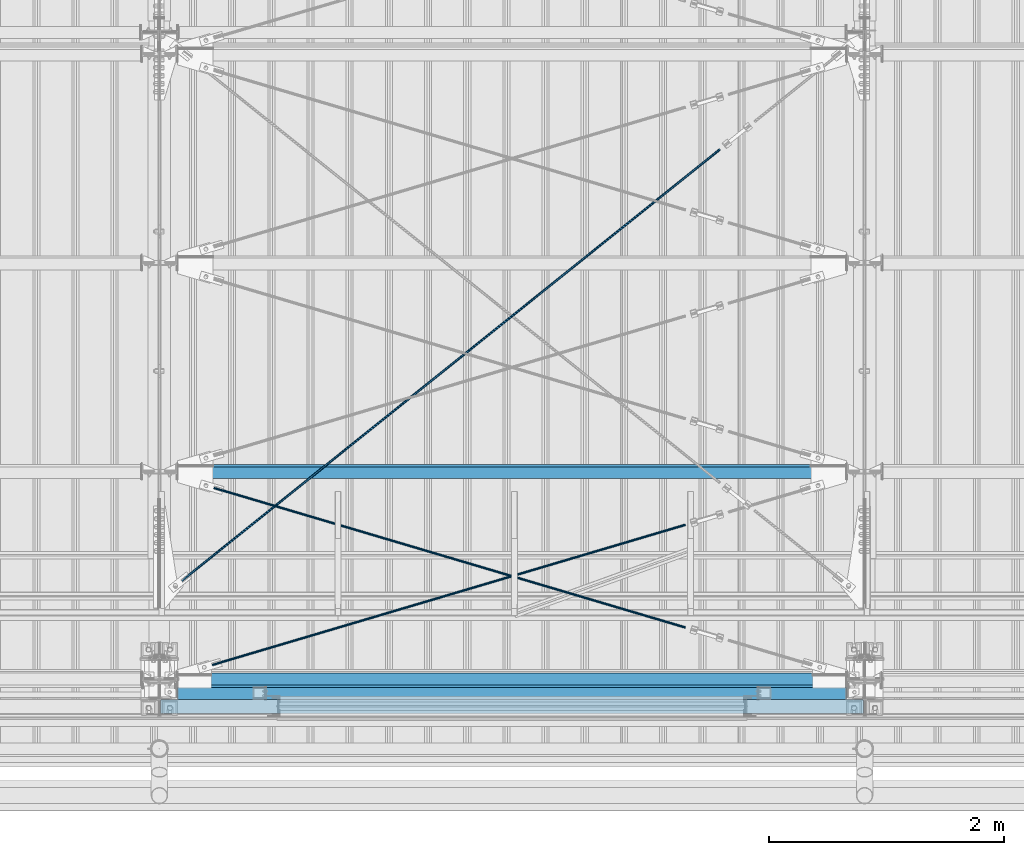
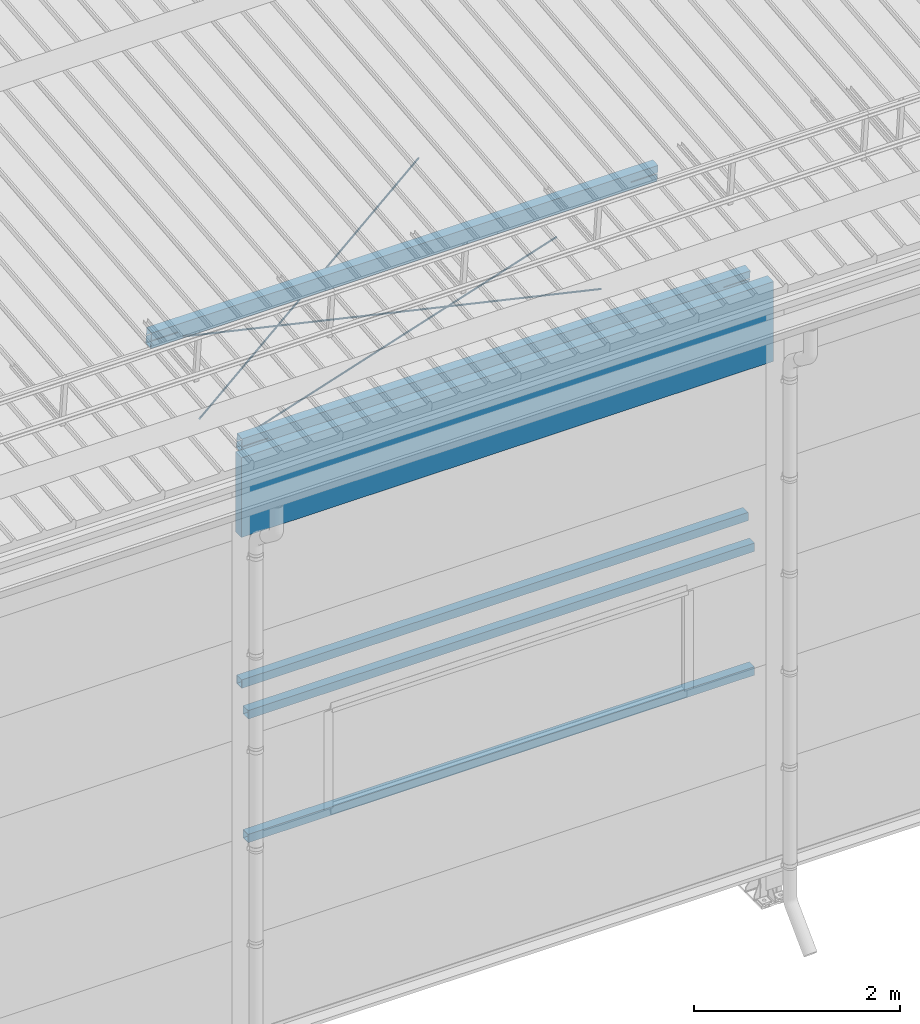
# One storey, part 273 of 709: 9 beams, 7 openings, 9 elements without a shape of their own.
"""IFC4 building model written with IfcOpenShell, lengths in millimetres."""

import ifcopenshell
import ifcopenshell.guid

model = None  # the IFC model being written
_history = None  # IfcOwnerHistory: only IFC2X3 demands one
_inside = {}  # id of a spatial element -> (the spatial element, [elements in it])
_under = {}  # id of a project, library or spatial element -> (it, [spatial elements below it])
_declared = {}  # id of a project -> (the project, [libraries it declares])
_typed = {}  # id of a type object -> (the type object, [elements of that type])
_made_of = {}  # id of a material, layer set ... -> (it, [elements and type objects made of it])


def new_model(schema):
    """Start an empty IFC model of exactly this schema.

    Asked for "IFC4X3", IfcOpenShell would pick the latest addendum, in which some entities
    have other attributes; the version numbers below select the first issue.
    IFC2X3 requires an IfcOwnerHistory on every rooted entity: one is made here for all.
    """
    global model, _history
    if schema == "IFC4X3":
        model = ifcopenshell.file(schema_version=(4, 3, 0, 0))
    else:
        model = ifcopenshell.file(schema=schema)
    _inside.clear()
    _under.clear()
    _declared.clear()
    _typed.clear()
    _made_of.clear()
    _history = None
    if model.schema == "IFC2X3":
        org = make("IfcOrganization", Name="unknown")
        user = make(
            "IfcPersonAndOrganization",
            ThePerson=make("IfcPerson", FamilyName="unknown"),
            TheOrganization=org,
        )
        app = make(
            "IfcApplication",
            ApplicationDeveloper=org,
            Version="unknown",
            ApplicationFullName="unknown",
            ApplicationIdentifier="unknown",
        )
        _history = make(
            "IfcOwnerHistory",
            OwningUser=user,
            OwningApplication=app,
            ChangeAction="ADDED",
            CreationDate=0,
        )
    return model


def make(cls, **values):
    """One entity of the class cls with the attributes given. An attribute that is None is left unset."""
    return model.create_entity(
        cls, **{name: value for name, value in values.items() if value is not None}
    )


def rooted(cls, **values):
    """An entity with a GlobalId (a new one), such as an element, a storey or a relation."""
    return make(cls, GlobalId=ifcopenshell.guid.new(), OwnerHistory=_history, **values)


def si_unit(unit_type, name, prefix=None):
    """IfcSIUnit, for example si_unit("LENGTHUNIT", "METRE", prefix="MILLI")."""
    return make("IfcSIUnit", UnitType=unit_type, Prefix=prefix, Name=name)


def assignment(units):
    """IfcUnitAssignment: the units of a project."""
    return None if units is None else make("IfcUnitAssignment", Units=units)


def point(xyz):
    """IfcCartesianPoint."""
    return None if xyz is None else make("IfcCartesianPoint", Coordinates=xyz)


def direction(xyz):
    """IfcDirection."""
    return None if xyz is None else make("IfcDirection", DirectionRatios=xyz)


def frame(location, z_axis=None, x_axis=None):
    """IfcAxis2Placement3D, a coordinate frame: its origin and axes. An axis left out is left unset."""
    return make(
        "IfcAxis2Placement3D",
        Location=point(location),
        Axis=direction(z_axis),
        RefDirection=direction(x_axis),
    )


def origin_with_axes():
    """The frame at (0, 0, 0) with the z axis (0, 0, 1) and the x axis (1, 0, 0) written out."""
    return frame((0.0, 0.0, 0.0), z_axis=(0.0, 0.0, 1.0), x_axis=(1.0, 0.0, 0.0))


def place(relative_to, where):
    """IfcLocalPlacement: puts the frame where relative to a parent placement (None: the world)."""
    return make(
        "IfcLocalPlacement", PlacementRelTo=relative_to, RelativePlacement=where
    )


def context(
    kind, dimensions, precision=None, world=None, true_north=None, identifier=None
):
    """IfcGeometricRepresentationContext, for example the 3D "Model" context."""
    return make(
        "IfcGeometricRepresentationContext",
        ContextIdentifier=identifier,
        ContextType=kind,
        CoordinateSpaceDimension=dimensions,
        Precision=precision,
        WorldCoordinateSystem=world,
        TrueNorth=true_north,
    )


def subcontext(parent, identifier, kind, view, scale=None):
    """IfcGeometricRepresentationSubContext, for example "Body" below "Model"."""
    return make(
        "IfcGeometricRepresentationSubContext",
        ContextIdentifier=identifier,
        ContextType=kind,
        ParentContext=parent,
        TargetScale=scale,
        TargetView=view,
    )


def project(units=None, contexts=None):
    """IfcProject with its units and contexts."""
    return rooted(
        "IfcProject",
        Name="project",
        RepresentationContexts=contexts,
        UnitsInContext=assignment(units),
    )


def spatial(cls, under=None, at=None, **own):
    """A site, building, storey or space (cls), placed at a placement, below another one or the project."""
    s = rooted(cls, ObjectPlacement=at, **own)
    if under is not None:
        _under.setdefault(under.id(), (under, []))[1].append(s)
    return s


def point_list(points):
    """IfcCartesianPointList2D or 3D."""
    cls = (
        "IfcCartesianPointList2D" if len(points[0]) == 2 else "IfcCartesianPointList3D"
    )
    return make(cls, CoordList=points)


def line(*indices):
    """IfcLineIndex: a straight run through numbered points of an indexed curve."""
    return model.create_entity("IfcLineIndex", indices)


def indexed_curve(points, segments=None, self_intersect=None):
    """IfcIndexedPolyCurve: lines and arcs through numbered points (the first is 1)."""
    return make(
        "IfcIndexedPolyCurve",
        Points=point_list(points),
        Segments=segments,
        SelfIntersect=self_intersect,
    )


def outline(outer, holes=None, kind="AREA"):
    """IfcArbitraryClosedProfileDef: a profile drawn as a closed curve; with holes, ...WithVoids."""
    if holes is None:
        return make("IfcArbitraryClosedProfileDef", ProfileType=kind, OuterCurve=outer)
    return make(
        "IfcArbitraryProfileDefWithVoids",
        ProfileType=kind,
        OuterCurve=outer,
        InnerCurves=holes,
    )


def extrude(swept, where, along, depth):
    """IfcExtrudedAreaSolid: the profile swept, set in the frame where, extruded along a direction by depth."""
    return make(
        "IfcExtrudedAreaSolid",
        SweptArea=swept,
        Position=where,
        ExtrudedDirection=direction(along),
        Depth=depth,
    )


def polygons(points, faces, closed=None, point_numbers=None):
    """IfcPolygonalFaceSet: a face is its outer loop, then its inner loops; points numbered from 1."""
    made = []
    for loops in faces:
        if len(loops) == 1:
            made.append(make("IfcIndexedPolygonalFace", CoordIndex=loops[0]))
        else:
            made.append(
                make(
                    "IfcIndexedPolygonalFaceWithVoids",
                    CoordIndex=loops[0],
                    InnerCoordIndices=loops[1:],
                )
            )
    return make(
        "IfcPolygonalFaceSet",
        Coordinates=point_list(points),
        Closed=closed,
        Faces=made,
        PnIndex=point_numbers,
    )


def shape(context_of_items, identifier, shape_type, items):
    """IfcShapeRepresentation: the items that make up one representation, for example the "Body"."""
    return make(
        "IfcShapeRepresentation",
        ContextOfItems=context_of_items,
        RepresentationIdentifier=identifier,
        RepresentationType=shape_type,
        Items=items,
    )


def material(Name=None, Category=None):
    """IfcMaterial."""
    return make("IfcMaterial", Name=Name, Category=Category)


def made_of(thing, what):
    """Note that an element or type object is made of a material, layer set ...; save() writes the relation."""
    if what is not None:
        _made_of.setdefault(what.id(), (what, []))[1].append(thing)
    return thing


def element(
    cls,
    number,
    at=None,
    inside=None,
    cuts=None,
    type_object=None,
    material=None,
    context=None,
    identifier="Body",
    shape_type=None,
    held_by="IfcProductDefinitionShape",
    body=None,
    shapes=None,
    **own,
):
    """One element of the class cls, such as IfcWall. Its Tag is "e" and its number.

    at: its placement. inside: the storey or other place that contains it. cuts: it is an
    opening in that element (IfcRelVoidsElement). A single representation is given by context,
    identifier, shape_type and body (its items); several are given by shapes. held_by: the class
    of the entity that holds the representations. save() writes the other relations.
    """
    e = rooted(cls, Tag="e%d" % number, ObjectPlacement=at, **own)
    if body is not None:
        shapes = [shape(context, identifier, shape_type, body)]
    if shapes is not None:
        e.Representation = make(held_by, Representations=shapes)
    if inside is not None:
        _inside.setdefault(inside.id(), (inside, []))[1].append(e)
    if cuts is not None:
        rooted(
            "IfcRelVoidsElement", RelatingBuildingElement=cuts, RelatedOpeningElement=e
        )
    if type_object is not None:
        _typed.setdefault(type_object.id(), (type_object, []))[1].append(e)
    return made_of(e, material)


def aggregate(whole, parts):
    """IfcRelAggregates: a whole, such as a stair, and the parts it consists of."""
    return rooted("IfcRelAggregates", RelatingObject=whole, RelatedObjects=parts)


def save(model, path):
    """Write the relations noted so far, then the file.

    IfcRelAggregates (storeys below a building ...), IfcRelContainedInSpatialStructure (elements
    in a storey), IfcRelDefinesByType, IfcRelAssociatesMaterial and IfcRelDeclares: one each for
    every whole, place, type object, material and project.
    """
    for whole, parts in _under.values():
        aggregate(whole, parts)
    for where, things in _inside.values():
        rooted(
            "IfcRelContainedInSpatialStructure",
            RelatedElements=things,
            RelatingStructure=where,
        )
    for kind, things in _typed.values():
        rooted("IfcRelDefinesByType", RelatedObjects=things, RelatingType=kind)
    for what, things in _made_of.values():
        rooted("IfcRelAssociatesMaterial", RelatedObjects=things, RelatingMaterial=what)
    for by, libraries in _declared.values():
        rooted("IfcRelDeclares", RelatingContext=by, RelatedDefinitions=libraries)
    model.write(path)


model = new_model("IFC4")

# Units and contexts
model_context = context("Model", 3, precision=0.2, world=origin_with_axes(), true_north=direction((0.0, 1.0)))
body_context = subcontext(model_context, "Body", "Model", "MODEL_VIEW")
reference_context = subcontext(model_context, "Reference", "Model", "MODEL_VIEW")
ifc_project = project(units=[si_unit("LENGTHUNIT", "METRE", prefix="MILLI"), si_unit("AREAUNIT", "SQUARE_METRE"), si_unit("VOLUMEUNIT", "CUBIC_METRE"), si_unit("MASSUNIT", "GRAM", prefix="KILO"), si_unit("TIMEUNIT", "SECOND"), si_unit("PLANEANGLEUNIT", "RADIAN"), si_unit("SOLIDANGLEUNIT", "STERADIAN"), si_unit("THERMODYNAMICTEMPERATUREUNIT", "DEGREE_CELSIUS"), si_unit("LUMINOUSINTENSITYUNIT", "LUMEN")], contexts=[model_context])

# Site, building, storey
site_placement = place(None, origin_with_axes())
site = spatial("IfcSite", under=ifc_project, at=site_placement, CompositionType="ELEMENT")
building_placement = place(site_placement, origin_with_axes())
building = spatial("IfcBuilding", under=site, at=building_placement, Name="Undefined", CompositionType="ELEMENT")
storey_placement = place(building_placement, origin_with_axes())
storey = spatial("IfcBuildingStorey", under=building, at=storey_placement, Name="Undefined", CompositionType="ELEMENT", Elevation=0.0)

# Assembly, beam, voiding feature
assembly_1_placement = place(storey_placement, frame((40000.0, 855.54834, 6946.69226), z_axis=(0.625451877, -0.7802627439, 1e-10), x_axis=(0.7742288439, 0.6206151549, -0.124123031)))
assembly_1 = element("IfcElementAssembly", 1, at=assembly_1_placement, inside=storey)
ifc_material_1 = material(Name="C355-5", Category="STEEL")
beam_1_placement = place(assembly_1_placement, origin_with_axes())
beam_1 = element("IfcBeam", 2, at=beam_1_placement, material=ifc_material_1, ObjectType="485", context=body_context, shape_type="Tessellation", body=[
    polygons([(6339.64669, 7.36122, 4.25), (6339.64669, 6.01041, 6.01041), (6339.64669, 4.25, 7.36122), (6339.64669, 2.19996, 8.21037), (6339.64669, 0.0, 8.5), (6339.64669, -2.19996, 8.21037), (6339.64669, -4.25, 7.36122), (6339.64669, -6.01041, 6.01041), (6339.64669, -7.36121, 4.25), (6339.64669, -8.21037, 2.19996), (6339.64669, -8.5, 0.0), (6339.64669, -8.21037, -2.19996), (6339.64669, -7.36121, -4.25), (6339.64669, -6.01041, -6.0104), (6339.64669, -4.25, -7.36121), (6339.64669, -2.19996, -8.21037), (6339.64669, 0.0, -8.5), (6339.64669, 2.19996, -8.21037), (6339.64669, 4.25, -7.36121), (6339.64669, 6.01041, -6.0104), (6339.64669, 7.36122, -4.25), (6339.64669, 8.21037, -2.19996), (6339.64669, 8.5, 0.0), (6339.64669, 8.21037, 2.19996), (6159.64669, 8.21037, 2.19996), (6159.64669, 7.36122, 4.25), (6159.64669, 6.01041, 6.01041), (6159.64669, 4.25, 7.36122), (6159.64669, 2.19996, 8.21037), (6159.64669, 0.0, 8.5), (6159.64669, -2.19996, 8.21037), (6159.64669, -4.25, 7.36122), (6159.64669, -6.01041, 6.01041), (6159.64669, -7.36121, 4.25), (6159.64669, -8.21037, 2.19996), (6159.64669, -8.5, 0.0), (6159.64669, -8.21037, -2.19996), (6159.64669, -7.36121, -4.25), (6159.64669, -6.01041, -6.0104), (6159.64669, -4.25, -7.36121), (6159.64669, -2.19996, -8.21037), (6159.64669, 0.0, -8.5), (6159.64669, 2.19996, -8.21037), (6159.64669, 4.25, -7.36121), (6159.64669, 6.01041, -6.0104), (6159.64669, 7.36122, -4.25), (6159.64669, 8.21037, -2.19996), (6159.64669, 8.5, 0.0), (6159.64669, 10.0, 0.0), (6159.64669, 9.65926, 2.58819), (6159.64669, 8.66025, 5.0), (6159.64669, 7.07107, 7.07107), (6159.64669, 5.0, 8.66025), (6159.64669, 2.58819, 9.65926), (6159.64669, 0.0, 10.0), (6159.64669, -2.58819, 9.65926), (6159.64669, -5.0, 8.66025), (6159.64669, -7.07107, 7.07107), (6159.64669, -8.66025, 5.0), (6159.64669, -9.65926, 2.58819), (6159.64669, -10.0, 0.0), (6159.64669, -9.65926, -2.58819), (6159.64669, -8.66025, -5.0), (6159.64669, -7.07107, -7.07107), (6159.64669, -5.0, -8.66025), (6159.64669, -2.58819, -9.65926), (6159.64669, 0.0, -10.0), (6159.64669, 2.58819, -9.65926), (6159.64669, 5.0, -8.66025), (6159.64669, 7.07107, -7.07107), (6159.64669, 8.66025, -5.0), (6159.64669, 9.65926, -2.58819), (246.65866, 2.58819, 9.65926), (246.65866, 5.0, 8.66025), (246.65866, 7.07107, 7.07107), (246.65866, 8.66025, 5.0), (246.65866, 9.65926, 2.58819), (246.65866, 10.0, 0.0), (246.65866, 9.65926, -2.58819), (246.65866, 8.66025, -5.0), (246.65866, 7.07107, -7.07107), (246.65866, 5.0, -8.66025), (246.65866, 2.58819, -9.65926), (246.65866, 0.0, -10.0), (246.65866, -2.58819, -9.65926), (246.65866, -5.0, -8.66025), (246.65866, -7.07107, -7.07107), (246.65866, -8.66025, -5.0), (246.65866, -9.65926, -2.58819), (246.65866, -10.0, 0.0), (246.65866, -9.65926, 2.58819), (246.65866, -8.66025, 5.0), (246.65866, -7.07107, 7.07107), (246.65866, -5.0, 8.66025), (246.65866, -2.58819, 9.65926), (246.65866, 0.0, 10.0)], [[[1, 2, 3, 4, 5, 6, 7, 8, 9, 10, 11, 12, 13, 14, 15, 16, 17, 18, 19, 20, 21, 22, 23, 24]], [[24, 25, 26, 1]], [[1, 26, 27, 2]], [[2, 27, 28, 3]], [[3, 28, 29, 4]], [[4, 29, 30, 5]], [[5, 30, 31, 6]], [[6, 31, 32, 7]], [[7, 32, 33, 8]], [[8, 33, 34, 9]], [[9, 34, 35, 10]], [[10, 35, 36, 11]], [[11, 36, 37, 12]], [[12, 37, 38, 13]], [[13, 38, 39, 14]], [[14, 39, 40, 15]], [[15, 40, 41, 16]], [[16, 41, 42, 17]], [[17, 42, 43, 18]], [[18, 43, 44, 19]], [[19, 44, 45, 20]], [[20, 45, 46, 21]], [[21, 46, 47, 22]], [[22, 47, 48, 23]], [[23, 48, 25, 24]], [[49, 50, 51, 52, 53, 54, 55, 56, 57, 58, 59, 60, 61, 62, 63, 64, 65, 66, 67, 68, 69, 70, 71, 72], [47, 46, 45, 44, 43, 42, 41, 40, 39, 38, 37, 36, 35, 34, 33, 32, 31, 30, 29, 28, 27, 26, 25, 48]], [[73, 74, 75, 76, 77, 78, 79, 80, 81, 82, 83, 84, 85, 86, 87, 88, 89, 90, 91, 92, 93, 94, 95, 96]], [[79, 78, 49, 72]], [[80, 79, 72, 71]], [[81, 80, 71, 70]], [[82, 81, 70, 69]], [[83, 82, 69, 68]], [[84, 83, 68, 67]], [[85, 84, 67, 66]], [[86, 85, 66, 65]], [[87, 86, 65, 64]], [[88, 87, 64, 63]], [[89, 88, 63, 62]], [[90, 89, 62, 61]], [[91, 90, 61, 60]], [[92, 91, 60, 59]], [[93, 92, 59, 58]], [[94, 93, 58, 57]], [[95, 94, 57, 56]], [[96, 95, 56, 55]], [[73, 96, 55, 54]], [[74, 73, 54, 53]], [[75, 74, 53, 52]], [[76, 75, 52, 51]], [[77, 76, 51, 50]], [[78, 77, 50, 49]]], closed=True),
])
voiding_feature_1_placement = place(beam_1_placement, frame((6339.64669, 0.0, 0.0), z_axis=(0.0, 1.0, 0.0), x_axis=(-1.0, 0.0, 0.0)))
element("IfcVoidingFeature", 3, at=voiding_feature_1_placement, cuts=beam_1, PredefinedType="HOLE", context=reference_context, identifier="Reference", shape_type="SolidModel", body=[
    extrude(outline(indexed_curve([(10.5, 0.0), (10.14222, 2.7176), (9.09327, 5.25), (7.42462, 7.42462), (5.25, 9.09327), (2.7176, 10.14222), (0.0, 10.5), (-2.7176, 10.14222), (-5.25, 9.09327), (-7.42462, 7.42462), (-9.09327, 5.25), (-10.14222, 2.7176), (-10.5, 0.0), (-10.14222, -2.7176), (-9.09327, -5.25), (-7.42462, -7.42462), (-5.25, -9.09327), (-2.7176, -10.14222), (0.0, -10.5), (2.7176, -10.14222), (5.25, -9.09327), (7.42462, -7.42462), (9.09327, -5.25), (10.14222, -2.7176)], segments=[line(1, 2, 3, 4, 5, 6, 7, 8, 9, 10, 11, 12, 13, 14, 15, 16, 17, 18, 19, 20, 21, 22, 23, 24, 1)])), frame((0.0, 0.0, 0.0), z_axis=(-1.0, 0.0, 0.0), x_axis=(0.0, 0.0, 1.0)), (0.0, 0.0, -1.0), 180.0),
])
aggregate(assembly_1, [beam_1])

# Assembly, beam
assembly_2_placement = place(storey_placement, frame((40000.0, 50.0, 2550.0), z_axis=(0.0, 0.0, -1.0), x_axis=(1.0, 0.0, 0.0)))
assembly_2 = element("IfcElementAssembly", 4, at=assembly_2_placement, inside=storey)
ifc_material_2 = material(Name="C355", Category="STEEL")
beam_2_placement = place(assembly_2_placement, origin_with_axes())
beam_2 = element("IfcBeam", 5, at=beam_2_placement, material=ifc_material_2, ObjectType="545", context=body_context, shape_type="Tessellation", body=[
    polygons([(155.0, -47.0, -47.0), (155.0, -47.0, 47.0), (5845.0, -47.0, 47.0), (5845.0, -47.0, -47.0), (155.0, 47.0, 47.0), (5845.0, 47.0, 47.0), (155.0, 47.0, -47.0), (5845.0, 47.0, -47.0), (155.0, -50.0, -50.0), (155.0, 50.0, -50.0), (5845.0, 50.0, -50.0), (5845.0, -50.0, -50.0), (155.0, 50.0, 50.0), (5845.0, 50.0, 50.0), (155.0, -50.0, 50.0), (5845.0, -50.0, 50.0)], [[[1, 2, 3, 4]], [[2, 5, 6, 3]], [[5, 7, 8, 6]], [[7, 1, 4, 8]], [[9, 10, 11, 12]], [[10, 13, 14, 11]], [[13, 15, 16, 14]], [[15, 9, 12, 16]], [[14, 16, 12, 11], [6, 8, 4, 3]], [[15, 13, 10, 9], [7, 5, 2, 1]]], closed=True),
])
aggregate(assembly_2, [beam_2])

assembly_3_placement = place(storey_placement, frame((40000.0, 50.0, 4020.0), z_axis=(0.0, 0.0, -1.0), x_axis=(1.0, 0.0, 0.0)))
assembly_3 = element("IfcElementAssembly", 6, at=assembly_3_placement, inside=storey)
beam_3_placement = place(assembly_3_placement, origin_with_axes())
beam_3 = element("IfcBeam", 7, at=beam_3_placement, material=ifc_material_2, ObjectType="545", context=body_context, shape_type="Tessellation", body=[
    polygons([(155.0, -47.0, -47.0), (155.0, -47.0, 47.0), (5845.0, -47.0, 47.0), (5845.0, -47.0, -47.0), (155.0, 47.0, 47.0), (5845.0, 47.0, 47.0), (155.0, 47.0, -47.0), (5845.0, 47.0, -47.0), (155.0, -50.0, -50.0), (155.0, 50.0, -50.0), (5845.0, 50.0, -50.0), (5845.0, -50.0, -50.0), (155.0, 50.0, 50.0), (5845.0, 50.0, 50.0), (155.0, -50.0, 50.0), (5845.0, -50.0, 50.0)], [[[1, 2, 3, 4]], [[2, 5, 6, 3]], [[5, 7, 8, 6]], [[7, 1, 4, 8]], [[9, 10, 11, 12]], [[10, 13, 14, 11]], [[13, 15, 16, 14]], [[15, 9, 12, 16]], [[14, 16, 12, 11], [6, 8, 4, 3]], [[15, 13, 10, 9], [7, 5, 2, 1]]], closed=True),
])
aggregate(assembly_3, [beam_3])

assembly_4_placement = place(storey_placement, frame((40000.0, 173.0, 4310.0), z_axis=(0.0, 0.0, -1.0), x_axis=(1.0, 0.0, 0.0)))
assembly_4 = element("IfcElementAssembly", 8, at=assembly_4_placement, inside=storey)
beam_4_placement = place(assembly_4_placement, origin_with_axes())
beam_4 = element("IfcBeam", 9, at=beam_4_placement, material=ifc_material_2, ObjectType="546", context=body_context, shape_type="Tessellation", body=[
    polygons([(155.0, -47.0, -47.0), (155.0, -47.0, 47.0), (5845.0, -47.0, 47.0), (5845.0, -47.0, -47.0), (155.0, 47.0, 47.0), (5845.0, 47.0, 47.0), (155.0, 47.0, -47.0), (5845.0, 47.0, -47.0), (155.0, -50.0, -50.0), (155.0, 50.0, -50.0), (5845.0, 50.0, -50.0), (5845.0, -50.0, -50.0), (155.0, 50.0, 50.0), (5845.0, 50.0, 50.0), (155.0, -50.0, 50.0), (5845.0, -50.0, 50.0)], [[[1, 2, 3, 4]], [[2, 5, 6, 3]], [[5, 7, 8, 6]], [[7, 1, 4, 8]], [[9, 10, 11, 12]], [[10, 13, 14, 11]], [[13, 15, 16, 14]], [[15, 9, 12, 16]], [[14, 16, 12, 11], [6, 8, 4, 3]], [[15, 13, 10, 9], [7, 5, 2, 1]]], closed=True),
])
aggregate(assembly_4, [beam_4])

# Assembly, beam, voiding feature
assembly_5_placement = place(storey_placement, frame((40000.0, 159.15434, 7152.41945), z_axis=(0.2852311229, -0.9537021177, -0.0953702118), x_axis=(0.9584587662, 0.2838155751, 0.028381558)))
assembly_5 = element("IfcElementAssembly", 10, at=assembly_5_placement, inside=storey)
beam_5_placement = place(assembly_5_placement, origin_with_axes())
beam_5 = element("IfcBeam", 11, at=beam_5_placement, material=ifc_material_1, ObjectType="568", context=body_context, shape_type="Tessellation", body=[
    polygons([(4850.05021, 7.36121, 4.25), (4850.05021, 6.01041, 6.01041), (4850.05021, 4.25, 7.36122), (4850.05021, 2.19996, 8.21037), (4850.05021, 0.0, 8.5), (4850.05021, -2.19996, 8.21037), (4850.05021, -4.25, 7.36122), (4850.05021, -6.01041, 6.01041), (4850.05021, -7.36122, 4.25), (4850.05021, -8.21037, 2.19996), (4850.05021, -8.5, 0.0), (4850.05021, -8.21037, -2.19996), (4850.05021, -7.36122, -4.25), (4850.05021, -6.01041, -6.01041), (4850.05021, -4.25, -7.36121), (4850.05021, -2.19996, -8.21037), (4850.05021, 0.0, -8.5), (4850.05021, 2.19996, -8.21037), (4850.05021, 4.25, -7.36121), (4850.05021, 6.01041, -6.01041), (4850.05021, 7.36121, -4.25), (4850.05021, 8.21037, -2.19996), (4850.05021, 8.5, 0.0), (4850.05021, 8.21037, 2.19996), (4670.05021, 8.21037, 2.19996), (4670.05021, 7.36121, 4.25), (4670.05021, 6.01041, 6.01041), (4670.05021, 4.25, 7.36122), (4670.05021, 2.19996, 8.21037), (4670.05021, 0.0, 8.5), (4670.05021, -2.19996, 8.21037), (4670.05021, -4.25, 7.36122), (4670.05021, -6.01041, 6.01041), (4670.05021, -7.36122, 4.25), (4670.05021, -8.21037, 2.19996), (4670.05021, -8.5, 0.0), (4670.05021, -8.21037, -2.19996), (4670.05021, -7.36122, -4.25), (4670.05021, -6.01041, -6.01041), (4670.05021, -4.25, -7.36121), (4670.05021, -2.19996, -8.21037), (4670.05021, 0.0, -8.5), (4670.05021, 2.19996, -8.21037), (4670.05021, 4.25, -7.36121), (4670.05021, 6.01041, -6.01041), (4670.05021, 7.36121, -4.25), (4670.05021, 8.21037, -2.19996), (4670.05021, 8.5, 0.0), (4670.05021, 10.0, 0.0), (4670.05021, 9.65926, 2.58819), (4670.05021, 8.66025, 5.0), (4670.05021, 7.07107, 7.07107), (4670.05021, 5.0, 8.66025), (4670.05021, 2.58819, 9.65926), (4670.05021, 0.0, 10.0), (4670.05021, -2.58819, 9.65926), (4670.05021, -5.0, 8.66025), (4670.05021, -7.07107, 7.07107), (4670.05021, -8.66025, 5.0), (4670.05021, -9.65926, 2.58819), (4670.05021, -10.0, 0.0), (4670.05021, -9.65926, -2.58819), (4670.05021, -8.66025, -5.0), (4670.05021, -7.07107, -7.07107), (4670.05021, -5.0, -8.66025), (4670.05021, -2.58819, -9.65926), (4670.05021, 0.0, -10.0), (4670.05021, 2.58819, -9.65926), (4670.05021, 5.0, -8.66025), (4670.05021, 7.07107, -7.07107), (4670.05021, 8.66025, -5.0), (4670.05021, 9.65926, -2.58819), (468.0251, 2.58819, 9.65926), (468.0251, 5.0, 8.66025), (468.0251, 7.07107, 7.07107), (468.0251, 8.66025, 5.0), (468.0251, 9.65926, 2.58819), (468.0251, 10.0, 0.0), (468.0251, 9.65926, -2.58819), (468.0251, 8.66025, -5.0), (468.0251, 7.07107, -7.07107), (468.0251, 5.0, -8.66025), (468.0251, 2.58819, -9.65926), (468.0251, 0.0, -10.0), (468.0251, -2.58819, -9.65926), (468.0251, -5.0, -8.66025), (468.0251, -7.07107, -7.07107), (468.0251, -8.66025, -5.0), (468.0251, -9.65926, -2.58819), (468.0251, -10.0, 0.0), (468.0251, -9.65926, 2.58819), (468.0251, -8.66025, 5.0), (468.0251, -7.07107, 7.07107), (468.0251, -5.0, 8.66025), (468.0251, -2.58819, 9.65926), (468.0251, 0.0, 10.0)], [[[1, 2, 3, 4, 5, 6, 7, 8, 9, 10, 11, 12, 13, 14, 15, 16, 17, 18, 19, 20, 21, 22, 23, 24]], [[24, 25, 26, 1]], [[1, 26, 27, 2]], [[2, 27, 28, 3]], [[3, 28, 29, 4]], [[4, 29, 30, 5]], [[5, 30, 31, 6]], [[6, 31, 32, 7]], [[7, 32, 33, 8]], [[8, 33, 34, 9]], [[9, 34, 35, 10]], [[10, 35, 36, 11]], [[11, 36, 37, 12]], [[12, 37, 38, 13]], [[13, 38, 39, 14]], [[14, 39, 40, 15]], [[15, 40, 41, 16]], [[16, 41, 42, 17]], [[17, 42, 43, 18]], [[18, 43, 44, 19]], [[19, 44, 45, 20]], [[20, 45, 46, 21]], [[21, 46, 47, 22]], [[22, 47, 48, 23]], [[23, 48, 25, 24]], [[49, 50, 51, 52, 53, 54, 55, 56, 57, 58, 59, 60, 61, 62, 63, 64, 65, 66, 67, 68, 69, 70, 71, 72], [47, 46, 45, 44, 43, 42, 41, 40, 39, 38, 37, 36, 35, 34, 33, 32, 31, 30, 29, 28, 27, 26, 25, 48]], [[73, 74, 75, 76, 77, 78, 79, 80, 81, 82, 83, 84, 85, 86, 87, 88, 89, 90, 91, 92, 93, 94, 95, 96]], [[79, 78, 49, 72]], [[80, 79, 72, 71]], [[81, 80, 71, 70]], [[82, 81, 70, 69]], [[83, 82, 69, 68]], [[84, 83, 68, 67]], [[85, 84, 67, 66]], [[86, 85, 66, 65]], [[87, 86, 65, 64]], [[88, 87, 64, 63]], [[89, 88, 63, 62]], [[90, 89, 62, 61]], [[91, 90, 61, 60]], [[92, 91, 60, 59]], [[93, 92, 59, 58]], [[94, 93, 58, 57]], [[95, 94, 57, 56]], [[96, 95, 56, 55]], [[73, 96, 55, 54]], [[74, 73, 54, 53]], [[75, 74, 53, 52]], [[76, 75, 52, 51]], [[77, 76, 51, 50]], [[78, 77, 50, 49]]], closed=True),
])
voiding_feature_2_placement = place(beam_5_placement, frame((4850.05021, 0.0, 0.0), z_axis=(0.0, 1.0, 0.0), x_axis=(-1.0, 0.0, 0.0)))
element("IfcVoidingFeature", 12, at=voiding_feature_2_placement, cuts=beam_5, PredefinedType="HOLE", context=reference_context, identifier="Reference", shape_type="SolidModel", body=[
    extrude(outline(indexed_curve([(10.5, 0.0), (10.14222, 2.7176), (9.09327, 5.25), (7.42462, 7.42462), (5.25, 9.09327), (2.7176, 10.14222), (0.0, 10.5), (-2.7176, 10.14222), (-5.25, 9.09327), (-7.42462, 7.42462), (-9.09327, 5.25), (-10.14222, 2.7176), (-10.5, 0.0), (-10.14222, -2.7176), (-9.09327, -5.25), (-7.42462, -7.42462), (-5.25, -9.09327), (-2.7176, -10.14222), (0.0, -10.5), (2.7176, -10.14222), (5.25, -9.09327), (7.42462, -7.42462), (9.09327, -5.25), (10.14222, -2.7176)], segments=[line(1, 2, 3, 4, 5, 6, 7, 8, 9, 10, 11, 12, 13, 14, 15, 16, 17, 18, 19, 20, 21, 22, 23, 24, 1)])), frame((0.0, 0.0, 0.0), z_axis=(-1.0, 0.0, 0.0), x_axis=(0.0, 0.0, 1.0)), (0.0, 0.0, -1.0), 180.0),
])
aggregate(assembly_5, [beam_5])

assembly_6_placement = place(storey_placement, frame((40000.0, 1935.85409, 7330.08943), z_axis=(-0.2852311229, -0.9537021177, -0.0953702118), x_axis=(0.9584587662, -0.2838155751, -0.028381558)))
assembly_6 = element("IfcElementAssembly", 13, at=assembly_6_placement, inside=storey)
beam_6_placement = place(assembly_6_placement, origin_with_axes())
beam_6 = element("IfcBeam", 14, at=beam_6_placement, material=ifc_material_1, ObjectType="570", context=body_context, shape_type="Tessellation", body=[
    polygons([(4850.05021, 7.36122, 4.25), (4850.05021, 6.01041, 6.01041), (4850.05021, 4.25, 7.36121), (4850.05021, 2.19996, 8.21037), (4850.05021, 0.0, 8.5), (4850.05021, -2.19996, 8.21037), (4850.05021, -4.25, 7.36121), (4850.05021, -6.01041, 6.01041), (4850.05021, -7.36121, 4.25), (4850.05021, -8.21037, 2.19996), (4850.05021, -8.5, 0.0), (4850.05021, -8.21037, -2.19996), (4850.05021, -7.36121, -4.25), (4850.05021, -6.01041, -6.01041), (4850.05021, -4.25, -7.36122), (4850.05021, -2.19996, -8.21037), (4850.05021, 0.0, -8.5), (4850.05021, 2.19996, -8.21037), (4850.05021, 4.25, -7.36122), (4850.05021, 6.01041, -6.01041), (4850.05021, 7.36122, -4.25), (4850.05021, 8.21037, -2.19996), (4850.05021, 8.5, 0.0), (4850.05021, 8.21037, 2.19996), (4670.05021, 8.21037, 2.19996), (4670.05021, 7.36122, 4.25), (4670.05021, 6.01041, 6.01041), (4670.05021, 4.25, 7.36121), (4670.05021, 2.19996, 8.21037), (4670.05021, 0.0, 8.5), (4670.05021, -2.19996, 8.21037), (4670.05021, -4.25, 7.36121), (4670.05021, -6.01041, 6.01041), (4670.05021, -7.36121, 4.25), (4670.05021, -8.21037, 2.19996), (4670.05021, -8.5, 0.0), (4670.05021, -8.21037, -2.19996), (4670.05021, -7.36121, -4.25), (4670.05021, -6.01041, -6.01041), (4670.05021, -4.25, -7.36122), (4670.05021, -2.19996, -8.21037), (4670.05021, 0.0, -8.5), (4670.05021, 2.19996, -8.21037), (4670.05021, 4.25, -7.36122), (4670.05021, 6.01041, -6.01041), (4670.05021, 7.36122, -4.25), (4670.05021, 8.21037, -2.19996), (4670.05021, 8.5, 0.0), (4670.05021, 10.0, 0.0), (4670.05021, 9.65926, 2.58819), (4670.05021, 8.66025, 5.0), (4670.05021, 7.07107, 7.07107), (4670.05021, 5.0, 8.66025), (4670.05021, 2.58819, 9.65926), (4670.05021, 0.0, 10.0), (4670.05021, -2.58819, 9.65926), (4670.05021, -5.0, 8.66025), (4670.05021, -7.07107, 7.07107), (4670.05021, -8.66025, 5.0), (4670.05021, -9.65926, 2.58819), (4670.05021, -10.0, 0.0), (4670.05021, -9.65926, -2.58819), (4670.05021, -8.66025, -5.0), (4670.05021, -7.07107, -7.07107), (4670.05021, -5.0, -8.66025), (4670.05021, -2.58819, -9.65926), (4670.05021, 0.0, -10.0), (4670.05021, 2.58819, -9.65926), (4670.05021, 5.0, -8.66025), (4670.05021, 7.07107, -7.07107), (4670.05021, 8.66025, -5.0), (4670.05021, 9.65926, -2.58819), (483.0251, 2.58819, 9.65926), (483.0251, 5.0, 8.66025), (483.0251, 7.07107, 7.07107), (483.0251, 8.66025, 5.0), (483.0251, 9.65926, 2.58819), (483.0251, 10.0, 0.0), (483.0251, 9.65926, -2.58819), (483.0251, 8.66025, -5.0), (483.0251, 7.07107, -7.07107), (483.0251, 5.0, -8.66025), (483.0251, 2.58819, -9.65926), (483.0251, 0.0, -10.0), (483.0251, -2.58819, -9.65926), (483.0251, -5.0, -8.66025), (483.0251, -7.07107, -7.07107), (483.0251, -8.66025, -5.0), (483.0251, -9.65926, -2.58819), (483.0251, -10.0, 0.0), (483.0251, -9.65926, 2.58819), (483.0251, -8.66025, 5.0), (483.0251, -7.07107, 7.07107), (483.0251, -5.0, 8.66025), (483.0251, -2.58819, 9.65926), (483.0251, 0.0, 10.0)], [[[1, 2, 3, 4, 5, 6, 7, 8, 9, 10, 11, 12, 13, 14, 15, 16, 17, 18, 19, 20, 21, 22, 23, 24]], [[24, 25, 26, 1]], [[1, 26, 27, 2]], [[2, 27, 28, 3]], [[3, 28, 29, 4]], [[4, 29, 30, 5]], [[5, 30, 31, 6]], [[6, 31, 32, 7]], [[7, 32, 33, 8]], [[8, 33, 34, 9]], [[9, 34, 35, 10]], [[10, 35, 36, 11]], [[11, 36, 37, 12]], [[12, 37, 38, 13]], [[13, 38, 39, 14]], [[14, 39, 40, 15]], [[15, 40, 41, 16]], [[16, 41, 42, 17]], [[17, 42, 43, 18]], [[18, 43, 44, 19]], [[19, 44, 45, 20]], [[20, 45, 46, 21]], [[21, 46, 47, 22]], [[22, 47, 48, 23]], [[23, 48, 25, 24]], [[49, 50, 51, 52, 53, 54, 55, 56, 57, 58, 59, 60, 61, 62, 63, 64, 65, 66, 67, 68, 69, 70, 71, 72], [47, 46, 45, 44, 43, 42, 41, 40, 39, 38, 37, 36, 35, 34, 33, 32, 31, 30, 29, 28, 27, 26, 25, 48]], [[73, 74, 75, 76, 77, 78, 79, 80, 81, 82, 83, 84, 85, 86, 87, 88, 89, 90, 91, 92, 93, 94, 95, 96]], [[79, 78, 49, 72]], [[80, 79, 72, 71]], [[81, 80, 71, 70]], [[82, 81, 70, 69]], [[83, 82, 69, 68]], [[84, 83, 68, 67]], [[85, 84, 67, 66]], [[86, 85, 66, 65]], [[87, 86, 65, 64]], [[88, 87, 64, 63]], [[89, 88, 63, 62]], [[90, 89, 62, 61]], [[91, 90, 61, 60]], [[92, 91, 60, 59]], [[93, 92, 59, 58]], [[94, 93, 58, 57]], [[95, 94, 57, 56]], [[96, 95, 56, 55]], [[73, 96, 55, 54]], [[74, 73, 54, 53]], [[75, 74, 53, 52]], [[76, 75, 52, 51]], [[77, 76, 51, 50]], [[78, 77, 50, 49]]], closed=True),
])
voiding_feature_3_placement = place(beam_6_placement, frame((4850.05021, 0.0, 0.0), z_axis=(0.0, 1.0, 0.0), x_axis=(-1.0, 0.0, 0.0)))
element("IfcVoidingFeature", 15, at=voiding_feature_3_placement, cuts=beam_6, PredefinedType="HOLE", context=reference_context, identifier="Reference", shape_type="SolidModel", body=[
    extrude(outline(indexed_curve([(10.5, 0.0), (10.14222, 2.7176), (9.09327, 5.25), (7.42462, 7.42462), (5.25, 9.09327), (2.7176, 10.14222), (0.0, 10.5), (-2.7176, 10.14222), (-5.25, 9.09327), (-7.42462, 7.42462), (-9.09327, 5.25), (-10.14222, 2.7176), (-10.5, 0.0), (-10.14222, -2.7176), (-9.09327, -5.25), (-7.42462, -7.42462), (-5.25, -9.09327), (-2.7176, -10.14222), (0.0, -10.5), (2.7176, -10.14222), (5.25, -9.09327), (7.42462, -7.42462), (9.09327, -5.25), (10.14222, -2.7176)], segments=[line(1, 2, 3, 4, 5, 6, 7, 8, 9, 10, 11, 12, 13, 14, 15, 16, 17, 18, 19, 20, 21, 22, 23, 24, 1)])), frame((0.0, 0.0, 0.0), z_axis=(-1.0, 0.0, 0.0), x_axis=(0.0, 0.0, 1.0)), (0.0, 0.0, -1.0), 180.0),
])
aggregate(assembly_6, [beam_6])

# Assembly, beam, voiding features
assembly_7_placement = place(storey_placement, frame((40000.0, 158.95533, 7154.40952), z_axis=(0.0, 0.9950371902, 0.099503719), x_axis=(1.0, 0.0, 0.0)))
assembly_7 = element("IfcElementAssembly", 16, at=assembly_7_placement, inside=storey)
beam_7_placement = place(assembly_7_placement, origin_with_axes())
beam_7 = element("IfcBeam", 17, at=beam_7_placement, material=ifc_material_2, ObjectType="565", context=body_context, shape_type="Tessellation", body=[
    polygons([(5855.0, 5.0, 50.0), (5855.0, 5.0, 46.0), (5557.75102, 5.0, 46.0), (5557.75102, 5.0, 50.0), (5557.75102, 15.0, 46.0), (5557.75102, 15.0, 50.0), (5855.0, 15.0, 50.0), (5855.0, 15.0, 46.0), (5855.0, 5.0, -46.0), (5855.0, 5.0, -50.0), (5557.75102, 5.0, -50.0), (5557.75102, 5.0, -46.0), (5557.75102, 15.0, -50.0), (5557.75102, 15.0, -46.0), (5855.0, 15.0, -46.0), (5855.0, 15.0, -50.0), (145.0, 86.0, 46.0), (145.0, 86.0, -46.0), (5855.0, 86.0, -46.0), (5855.0, 86.0, 46.0), (5855.0, -86.0, 46.0), (145.0, -86.0, 46.0), (145.0, 5.0, 46.0), (442.24898, 5.0, 46.0), (442.24898, 15.0, 46.0), (145.0, 15.0, 46.0), (145.0, -86.0, -46.0), (5855.0, -86.0, -46.0), (145.0, 15.0, -46.0), (145.0, 15.0, -50.0), (442.24898, 15.0, -50.0), (442.24898, 15.0, -46.0), (442.24898, 5.0, -50.0), (442.24898, 5.0, -46.0), (145.0, 5.0, -50.0), (145.0, 5.0, -46.0), (145.0, -90.0, -50.0), (145.0, -90.0, 50.0), (145.0, 5.0, 50.0), (442.24898, 5.0, 50.0), (442.24898, 15.0, 50.0), (145.0, 15.0, 50.0), (145.0, 90.0, 50.0), (145.0, 90.0, -50.0), (5855.0, 90.0, 50.0), (5855.0, 90.0, -50.0), (5855.0, -90.0, -50.0), (5855.0, -90.0, 50.0)], [[[1, 2, 3, 4]], [[4, 3, 5, 6]], [[7, 6, 5, 8]], [[9, 10, 11, 12]], [[12, 11, 13, 14]], [[15, 14, 13, 16]], [[17, 18, 19, 20]], [[3, 2, 21, 22, 23, 24, 25, 26, 17, 20, 8, 5]], [[27, 22, 21, 28]], [[29, 30, 31, 32]], [[32, 31, 33, 34]], [[34, 33, 35, 36]], [[22, 27, 36, 35, 37, 38, 39, 23]], [[40, 24, 23, 39]], [[41, 25, 24, 40]], [[42, 26, 25, 41]], [[43, 44, 30, 29, 18, 17, 26, 42]], [[44, 43, 45, 46]], [[20, 19, 15, 16, 46, 45, 7, 8]], [[11, 10, 47, 37, 35, 33, 31, 30, 44, 46, 16, 13]], [[38, 37, 47, 48]], [[45, 43, 42, 41, 40, 39, 38, 48, 1, 4, 6, 7]], [[48, 47, 10, 9, 28, 21, 2, 1]], [[19, 18, 29, 32, 34, 36, 27, 28, 9, 12, 14, 15]]], closed=True),
])
voiding_feature_4_placement = place(beam_7_placement, frame((145.0, 10.0, -70.0), z_axis=(0.0, -1.0, 0.0), x_axis=(1.0, 0.0, 0.0)))
element("IfcVoidingFeature", 18, at=voiding_feature_4_placement, cuts=beam_7, PredefinedType="HOLE", context=reference_context, identifier="Reference", shape_type="SolidModel", body=[
    extrude(outline(indexed_curve([(0.0, 0.0), (297.24898, 0.0), (297.24898, 154.66006), (271.57818, 240.92135), (0.0, 160.10144)], segments=[line(1, 2, 3, 4, 5, 1)])), frame((0.0, 0.0, 5.0), z_axis=(0.0, 0.0, 1.0), x_axis=(1.0, 0.0, 0.0)), (0.0, 0.0, -1.0), 10.0),
])
voiding_feature_5_placement = place(beam_7_placement, frame((5557.75102, 10.0, -70.0), z_axis=(0.0, -1.0, 0.0), x_axis=(1.0, 0.0, 0.0)))
element("IfcVoidingFeature", 19, at=voiding_feature_5_placement, cuts=beam_7, PredefinedType="HOLE", context=reference_context, identifier="Reference", shape_type="SolidModel", body=[
    extrude(outline(indexed_curve([(0.0, 0.0), (297.24898, 0.0), (297.24898, 160.10144), (25.6708, 240.92135), (0.0, 154.66006)], segments=[line(1, 2, 3, 4, 5, 1)])), frame((0.0, 0.0, 5.0), z_axis=(0.0, 0.0, 1.0), x_axis=(1.0, 0.0, 0.0)), (0.0, 0.0, -1.0), 10.0),
])
aggregate(assembly_7, [beam_7])

assembly_8_placement = place(storey_placement, frame((40000.0, 1936.65012, 7322.12913), z_axis=(0.0, 0.9950371902, 0.099503719), x_axis=(1.0, 0.0, 0.0)))
assembly_8 = element("IfcElementAssembly", 20, at=assembly_8_placement, inside=storey)
beam_8_placement = place(assembly_8_placement, origin_with_axes())
beam_8 = element("IfcBeam", 21, at=beam_8_placement, material=ifc_material_2, ObjectType="566", context=body_context, shape_type="Tessellation", body=[
    polygons([(5845.0, -5.0, 50.0), (5845.0, -5.0, 46.0), (5543.37414, -5.0, 46.0), (5543.37414, -5.0, 50.0), (5543.37414, 5.0, 46.0), (5543.37414, 5.0, 50.0), (5845.00055, 5.0, 50.0), (5845.0, 5.0, 46.0), (5845.0, -5.0, -46.0), (5845.0, -5.0, -50.0), (5543.37413, -5.0, -50.0), (5543.37413, -5.0, -46.0), (5543.37413, 5.0, -50.0), (5543.37413, 5.0, -46.0), (5845.00055, 5.0, -46.0), (5845.0, 5.0, -50.0), (155.0, 96.0, 46.0), (155.0, 96.0, -46.0), (5845.0, 96.0, -46.0), (5845.0, 96.0, 46.0), (5845.0, -96.0, 46.0), (155.0, -96.0, 46.0), (155.0, -5.0, 46.0), (456.62587, -5.0, 46.0), (456.62587, 5.0, 46.0), (155.0, 5.0, 46.0), (155.0, -96.0, -46.0), (5845.0, -96.0, -46.0), (155.0, 5.0, -46.0), (155.0, 5.0, -50.0), (456.62587, 5.0, -50.0), (456.62587, 5.0, -46.0), (456.62587, -5.0, -50.0), (456.62587, -5.0, -46.0), (155.0, -5.0, -50.0), (155.0, -5.0, -46.0), (155.0, -100.0, -50.0), (155.0, -100.0, 50.0), (155.0, -5.0, 50.0), (456.62587, -5.0, 50.0), (456.62587, 5.0, 50.0), (155.0, 5.0, 50.0), (155.0, 100.0, 50.0), (155.0, 100.0, -50.0), (5845.0, 100.0, 50.0), (5845.0, 100.0, -50.0), (5845.0, -100.0, -50.0), (5845.0, -100.0, 50.0)], [[[1, 2, 3, 4]], [[4, 3, 5, 6]], [[7, 6, 5, 8]], [[9, 10, 11, 12]], [[12, 11, 13, 14]], [[15, 14, 13, 16]], [[17, 18, 19, 20]], [[3, 2, 21, 22, 23, 24, 25, 26, 17, 20, 8, 5]], [[27, 22, 21, 28]], [[29, 30, 31, 32]], [[32, 31, 33, 34]], [[34, 33, 35, 36]], [[22, 27, 36, 35, 37, 38, 39, 23]], [[40, 24, 23, 39]], [[41, 25, 24, 40]], [[42, 26, 25, 41]], [[43, 44, 30, 29, 18, 17, 26, 42]], [[44, 43, 45, 46]], [[20, 19, 15, 16, 46, 45, 7, 8]], [[11, 10, 47, 37, 35, 33, 31, 30, 44, 46, 16, 13]], [[38, 37, 47, 48]], [[45, 43, 42, 41, 40, 39, 38, 48, 1, 4, 6, 7]], [[48, 47, 10, 9, 28, 21, 2, 1]], [[19, 18, 29, 32, 34, 36, 27, 28, 9, 12, 14, 15]]], closed=True),
])
voiding_feature_6_placement = place(beam_8_placement, frame((154.99945, 0.0, 93.07721), z_axis=(0.0, -1.0, 0.0), x_axis=(0.0, 0.0, -1.0)))
element("IfcVoidingFeature", 22, at=voiding_feature_6_placement, cuts=beam_8, Name="PLATE", PredefinedType="HOLE", context=reference_context, identifier="Reference", shape_type="SolidModel", body=[
    extrude(outline(indexed_curve([(0.0, 0.0), (186.15442, 0.0), (268.27702, 275.95562), (182.01573, 301.62642), (4.13868, 301.62642), (-82.1226, 275.95562)], segments=[line(1, 2, 3, 4, 5, 6, 1)])), frame((0.0, 0.0, 5.0), z_axis=(0.0, 0.0, 1.0), x_axis=(1.0, 0.0, 0.0)), (0.0, 0.0, -1.0), 10.0),
])
voiding_feature_7_placement = place(beam_8_placement, frame((5845.00055, 0.0, -93.07721), z_axis=(0.0, -1.0, 0.0), x_axis=(0.0, 0.0, 1.0)))
element("IfcVoidingFeature", 23, at=voiding_feature_7_placement, cuts=beam_8, Name="PLATE", PredefinedType="HOLE", context=reference_context, identifier="Reference", shape_type="SolidModel", body=[
    extrude(outline(indexed_curve([(0.0, 0.0), (186.15442, 0.0), (268.27702, 275.95562), (182.01573, 301.62642), (4.13868, 301.62642), (-82.1226, 275.95562)], segments=[line(1, 2, 3, 4, 5, 6, 1)])), frame((0.0, 0.0, 5.0), z_axis=(0.0, 0.0, 1.0), x_axis=(1.0, 0.0, 0.0)), (0.0, 0.0, -1.0), 10.0),
])
aggregate(assembly_8, [beam_8])

# Assembly, beam
assembly_9_placement = place(storey_placement, frame((40010.0, -60.0, 6845.0), z_axis=(0.0, 0.0, -1.0), x_axis=(1.0, 0.0, 0.0)))
assembly_9 = element("IfcElementAssembly", 24, at=assembly_9_placement, inside=storey)
ifc_material_3 = material(Name="Insulation", Category="Insulation")
beam_9_placement = place(assembly_9_placement, origin_with_axes())
beam_9 = element("IfcBeam", 25, at=beam_9_placement, material=ifc_material_3, ObjectType="P-108", context=body_context, shape_type="Tessellation", body=[
    polygons([(0.0, 60.0, 595.0), (0.0, -60.0, 595.0), (5980.0, -60.0, 595.0), (5980.0, 60.0, 595.0), (5980.0, 60.0, -351.923), (0.0, 60.0, -351.923), (0.0, -60.0, -351.923), (5980.0, -60.0, -351.923)], [[[1, 2, 3, 4]], [[1, 4, 5, 6]], [[2, 1, 6, 7]], [[3, 2, 7, 8]], [[4, 3, 8, 5]], [[7, 6, 5, 8]]], closed=True),
])
aggregate(assembly_9, [beam_9])

save(model, "model.ifc")
